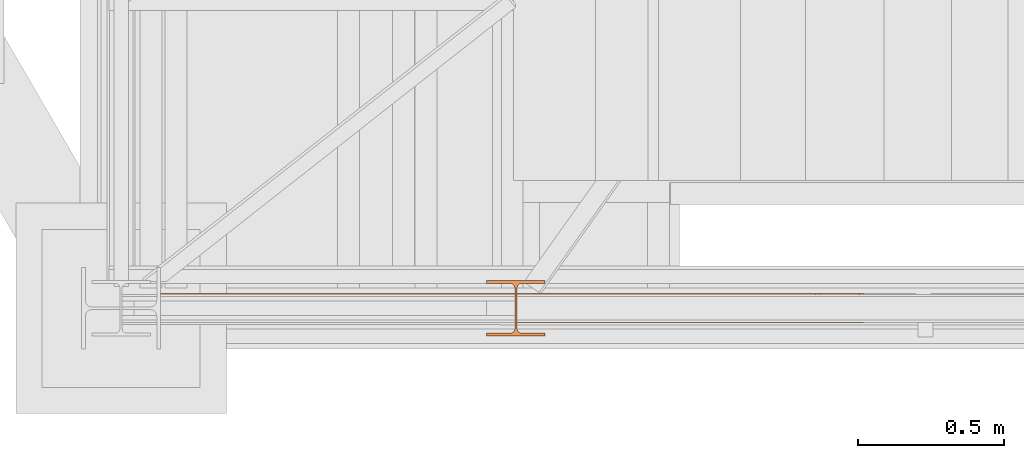
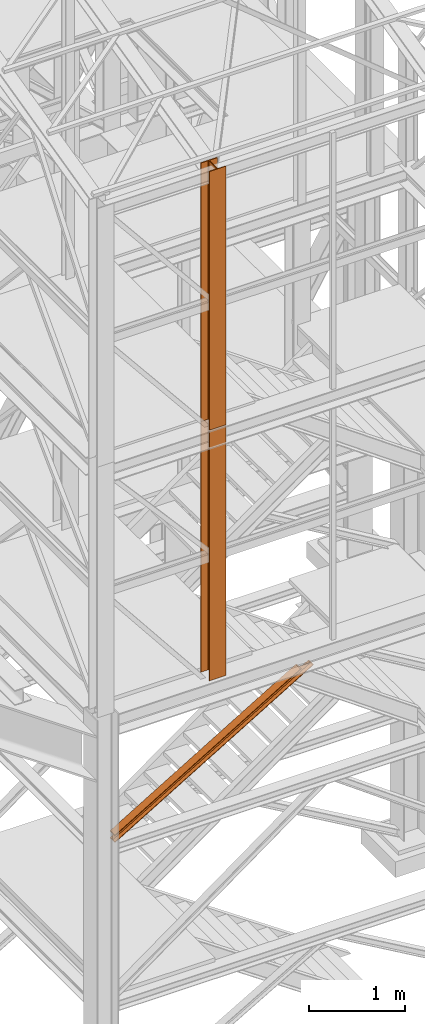
# One storey, part 7 of 208: 3 proxies.
"""IFC2X3 building model written with IfcOpenShell, lengths in millimetres."""

from ifc_helpers import new_model, entity, si_unit, converted_unit, frame, origin, origin_with_axes, place, context, subcontext, project, spatial, faceted_brep, element, save


model = new_model("IFC2X3")

# Units and contexts
model_context = context("Model", 3, precision=1e-05, world=origin())
plan_context = context("Plan", 3, precision=1e-05, world=origin())
body_context = subcontext(model_context, "Body", "Model", "MODEL_VIEW")
ifc_project = project(units=[si_unit("LENGTHUNIT", "METRE", prefix="MILLI"), converted_unit("PLANEANGLEUNIT", "DEGREE", entity("IfcPlaneAngleMeasure", 0.0174532925199433), si_unit("PLANEANGLEUNIT", "RADIAN"), dimensions=[0, 0, 0, 0, 0, 0, 0]), si_unit("AREAUNIT", "SQUARE_METRE"), si_unit("VOLUMEUNIT", "CUBIC_METRE")], contexts=[model_context, plan_context])

# Building, storey
building_placement = place(None, origin())
building = spatial("IfcBuilding", under=ifc_project, at=building_placement, CompositionType="COMPLEX")
storey_placement = place(building_placement, origin_with_axes())
storey = spatial("IfcBuildingStorey", under=building, at=storey_placement, Name="Geschoss", CompositionType="ELEMENT")

# Proxies
proxy_1_placement = place(storey_placement, frame((1333.254973893077, -25222.57439031789, 3580.490000221249), z_axis=(0.0, 0.0, 1.0), x_axis=(1.0, 0.0, 0.0)))
element("IfcBuildingElementProxy", 1, at=proxy_1_placement, inside=storey, context=body_context, shape_type="Brep", body=[
    faceted_brep([(0.009999999999990905, 0.00999999999839929, 88.01000000000022), (0.009999999999990905, 47.5099999999984, 88.01000000000022), (0.009999999999990905, 47.5099999999984, 8.010000000000218), (0.009999999999990905, 0.00999999999839929, 8.010000000000218), (0.009999999999990905, 0.00999999999839929, 0.01000000000021828), (0.009999999999990905, 100.0099999999984, 0.01000000000021828), (0.009999999999990905, 100.0099999999984, 8.010000000000218), (0.009999999999990905, 52.5099999999984, 8.010000000000218), (0.009999999999990905, 52.5099999999984, 88.01000000000022), (0.009999999999990905, 100.0099999999984, 88.01000000000022), (0.009999999999990905, 100.0099999999984, 96.01000000000022), (0.009999999999990905, 0.00999999999839929, 96.01000000000022), (0.009999999999990905, 0.00999999999839929, 96.01000000000022), (2238.627931874558, 0.01000000000203727, 1434.509994414331), (2252.314552726377, 0.01000000000203727, 1434.509994414331), (0.009999999999990905, 0.00999999999839929, 88.01000000000022), (0.009999999999990905, 100.0099999999984, 96.01000000000022), (2238.627931874558, 100.010000000002, 1434.509994414331), (2238.627931874558, 0.01000000000203727, 1434.509994414331), (0.009999999999990905, 0.00999999999839929, 96.01000000000022), (0.009999999999990905, 100.0099999999984, 88.01000000000022), (2252.314552726377, 100.0100000000057, 1434.509994414331), (2238.627931874558, 100.010000000002, 1434.509994414331), (0.009999999999990905, 100.0099999999984, 96.01000000000022), (0.009999999999990905, 52.5099999999984, 88.01000000000022), (2252.314552726377, 52.51000000000204, 1434.509994414331), (2252.314552726377, 100.0100000000057, 1434.509994414331), (0.009999999999990905, 100.0099999999984, 88.01000000000022), (0.009999999999990905, 52.5099999999984, 8.010000000000218), (2389.180761244557, 52.51000000000568, 1434.509994414331), (2252.314552726377, 52.51000000000204, 1434.509994414331), (0.009999999999990905, 52.5099999999984, 88.01000000000022), (0.009999999999990905, 100.0099999999984, 8.010000000000218), (2389.180761244556, 100.0100000000057, 1434.509994414332), (2389.180761244557, 52.51000000000568, 1434.509994414331), (0.009999999999990905, 52.5099999999984, 8.010000000000218), (0.009999999999990905, 100.0099999999984, 0.01000000000021828), (2402.867382096375, 100.0100000000057, 1434.509994414331), (2389.180761244556, 100.0100000000057, 1434.509994414332), (0.009999999999990905, 100.0099999999984, 8.010000000000218), (0.009999999999990905, 0.00999999999839929, 0.01000000000021828), (2402.867382096375, 0.01000000000567525, 1434.509994414331), (2402.867382096375, 100.0100000000057, 1434.509994414331), (0.009999999999990905, 100.0099999999984, 0.01000000000021828), (0.009999999999990905, 0.00999999999839929, 8.010000000000218), (2389.180761244557, 0.01000000000567525, 1434.509994414331), (2402.867382096375, 0.01000000000567525, 1434.509994414331), (0.009999999999990905, 0.00999999999839929, 0.01000000000021828), (0.009999999999990905, 47.5099999999984, 8.010000000000218), (2389.180761244556, 47.51000000000204, 1434.509994414332), (2389.180761244557, 0.01000000000567525, 1434.509994414331), (0.009999999999990905, 0.00999999999839929, 8.010000000000218), (0.009999999999990905, 47.5099999999984, 88.01000000000022), (2252.314552726377, 47.51000000000204, 1434.509994414331), (2389.180761244556, 47.51000000000204, 1434.509994414332), (0.009999999999990905, 47.5099999999984, 8.010000000000218), (0.009999999999990905, 0.00999999999839929, 88.01000000000022), (2252.314552726377, 0.01000000000203727, 1434.509994414331), (2252.314552726377, 47.51000000000204, 1434.509994414331), (0.009999999999990905, 47.5099999999984, 88.01000000000022), (2238.627931874558, 0.01000000000203727, 1434.509994414331), (2238.627931874558, 100.010000000002, 1434.509994414331), (2252.314552726377, 100.0100000000057, 1434.509994414331), (2252.314552726377, 52.51000000000204, 1434.509994414331), (2389.180761244557, 52.51000000000568, 1434.509994414331), (2389.180761244556, 100.0100000000057, 1434.509994414332), (2402.867382096375, 100.0100000000057, 1434.509994414331), (2402.867382096375, 0.01000000000567525, 1434.509994414331), (2389.180761244557, 0.01000000000567525, 1434.509994414331), (2389.180761244556, 47.51000000000204, 1434.509994414332), (2252.314552726377, 47.51000000000204, 1434.509994414331), (2252.314552726377, 0.01000000000203727, 1434.509994414331)], [[[0, 1, 2, 3, 4, 5, 6, 7, 8, 9, 10, 11]], [[12, 13, 14, 15]], [[16, 17, 18, 19]], [[20, 21, 22, 23]], [[24, 25, 26, 27]], [[28, 29, 30, 31]], [[32, 33, 34, 35]], [[36, 37, 38, 39]], [[40, 41, 42, 43]], [[44, 45, 46, 47]], [[48, 49, 50, 51]], [[52, 53, 54, 55]], [[56, 57, 58, 59]], [[60, 61, 62, 63, 64, 65, 66, 67, 68, 69, 70, 71]]], orient=[[False], [False], [False], [False], [False], [False], [False], [False], [False], [False], [False], [False], [False], [False]]),
])
proxy_2_placement = place(storey_placement, frame((2448.254967038549, -25267.57438790133, 5284.990005364416), z_axis=(0.0, 0.0, 1.0), x_axis=(1.0, 0.0, 0.0)))
element("IfcBuildingElementProxy", 2, at=proxy_2_placement, inside=storey, context=body_context, shape_type="Brep", body=[
    faceted_brep([(0.01000000000112777, 190.0100125169738, 3200.009996721741), (200.0100029802334, 190.0100125169738, 3200.009996721741), (200.0100029802334, 180.0100146031364, 3200.009996721741), (121.2600035762798, 180.0100071525558, 3200.009996721741), (111.9441915473353, 178.1454621052726, 3200.009996721741), (105.1245498640847, 171.3258190250381, 3200.009996721741), (103.2600015571725, 162.0100079274162, 3200.009996721741), (103.2600015571725, 28.00999713897545, 3200.009996721741), (105.1245498640847, 18.69418604135353, 3200.009996721741), (111.9441915473353, 11.87454296111901, 3200.009996721741), (121.2600035762798, 10.00999791383583, 3200.009996721741), (200.0100029802334, 10.00999791383583, 3200.009996721741), (200.0100029802334, 0.00999999999839929, 3200.009996721741), (0.01000000000112777, 0.00999999999839929, 3200.009996721741), (0.01000000000112777, 10.00999791383583, 3200.009996721741), (78.75999940395468, 10.00999791383583, 3200.009996721741), (88.07581143289917, 11.87454296111901, 3200.009996721741), (94.89545311614984, 18.69418604135353, 3200.009996721741), (96.76000142306202, 28.00999713897545, 3200.009996721741), (96.76000142306202, 162.0100079274162, 3200.009996721741), (94.89545311614984, 171.3258190250381, 3200.009996721741), (88.07581143289917, 178.1454621052726, 3200.009996721741), (78.75999940395468, 180.0100071525558, 3200.009996721741), (0.01000000000112777, 180.0100146031364, 3200.009996721741), (200.0100029802334, 190.0100125169738, 3200.009996721741), (0.01000000000112777, 190.0100125169738, 3200.009996721741), (0.01000000000021828, 190.0100125169738, 0.009999999999308784), (200.0100029802325, 190.0100125169738, 0.009999999999308784), (200.0100029802334, 180.0100146031364, 3200.009996721741), (200.0100029802334, 190.0100125169738, 3200.009996721741), (200.0100029802325, 190.0100125169738, 0.009999999999308784), (200.0100029802325, 180.0100146031364, 0.009999999999308784), (121.2600035762798, 180.0100071525558, 3200.009996721741), (200.0100029802334, 180.0100146031364, 3200.009996721741), (200.0100029802325, 180.0100146031364, 0.009999999999308784), (121.2600035762789, 180.0100071525558, 0.009999999999308784), (111.9441915473353, 178.1454621052726, 3200.009996721741), (121.2600035762798, 180.0100071525558, 3200.009996721741), (121.2600035762789, 180.0100071525558, 0.009999999999308784), (111.9441915473344, 178.1454621052726, 0.009999999999308784), (105.1245498640847, 171.3258190250381, 3200.009996721741), (111.9441915473353, 178.1454621052726, 3200.009996721741), (111.9441915473344, 178.1454621052726, 0.009999999999308784), (105.1245498640838, 171.3258190250381, 0.009999999999308784), (103.2600015571725, 162.0100079274162, 3200.009996721741), (105.1245498640847, 171.3258190250381, 3200.009996721741), (105.1245498640838, 171.3258190250381, 0.009999999999308784), (103.2600015571716, 162.0100079274162, 0.009999999999308784), (103.2600015571725, 28.00999713897545, 3200.009996721741), (103.2600015571725, 162.0100079274162, 3200.009996721741), (103.2600015571716, 162.0100079274162, 0.009999999999308784), (103.2600015571716, 28.00999713897545, 0.009999999999308784), (105.1245498640847, 18.69418604135353, 3200.009996721741), (103.2600015571725, 28.00999713897545, 3200.009996721741), (103.2600015571716, 28.00999713897545, 0.009999999999308784), (105.1245498640838, 18.69418604135353, 0.009999999999308784), (111.9441915473353, 11.87454296111901, 3200.009996721741), (105.1245498640847, 18.69418604135353, 3200.009996721741), (105.1245498640838, 18.69418604135353, 0.009999999999308784), (111.9441915473344, 11.87454296111901, 0.009999999999308784), (121.2600035762798, 10.00999791383583, 3200.009996721741), (111.9441915473353, 11.87454296111901, 3200.009996721741), (111.9441915473344, 11.87454296111901, 0.009999999999308784), (121.2600035762789, 10.00999791383583, 0.009999999999308784), (200.0100029802334, 10.00999791383583, 3200.009996721741), (121.2600035762798, 10.00999791383583, 3200.009996721741), (121.2600035762789, 10.00999791383583, 0.009999999999308784), (200.0100029802325, 10.00999791383583, 0.009999999999308784), (200.0100029802334, 0.00999999999839929, 3200.009996721741), (200.0100029802334, 10.00999791383583, 3200.009996721741), (200.0100029802325, 10.00999791383583, 0.009999999999308784), (200.0100029802325, 0.00999999999839929, 0.009999999999308784), (0.01000000000112777, 0.00999999999839929, 3200.009996721741), (200.0100029802334, 0.00999999999839929, 3200.009996721741), (200.0100029802325, 0.00999999999839929, 0.009999999999308784), (0.01000000000021828, 0.00999999999839929, 0.009999999999308784), (0.01000000000112777, 10.00999791383583, 3200.009996721741), (0.01000000000112777, 0.00999999999839929, 3200.009996721741), (0.01000000000021828, 0.00999999999839929, 0.009999999999308784), (0.01000000000021828, 10.00999791383583, 0.009999999999308784), (78.75999940395468, 10.00999791383583, 3200.009996721741), (0.01000000000112777, 10.00999791383583, 3200.009996721741), (0.01000000000021828, 10.00999791383583, 0.009999999999308784), (78.75999940395377, 10.00999791383583, 0.009999999999308784), (88.07581143289917, 11.87454296111901, 3200.009996721741), (78.75999940395468, 10.00999791383583, 3200.009996721741), (78.75999940395377, 10.00999791383583, 0.009999999999308784), (88.07581143289826, 11.87454296111901, 0.009999999999308784), (94.89545311614984, 18.69418604135353, 3200.009996721741), (88.07581143289917, 11.87454296111901, 3200.009996721741), (88.07581143289826, 11.87454296111901, 0.009999999999308784), (94.89545311614893, 18.69418604135353, 0.009999999999308784), (96.76000142306202, 28.00999713897545, 3200.009996721741), (94.89545311614984, 18.69418604135353, 3200.009996721741), (94.89545311614893, 18.69418604135353, 0.009999999999308784), (96.76000142306111, 28.00999713897545, 0.009999999999308784), (96.76000142306202, 162.0100079274162, 3200.009996721741), (96.76000142306202, 28.00999713897545, 3200.009996721741), (96.76000142306111, 28.00999713897545, 0.009999999999308784), (96.76000142306111, 162.0100079274162, 0.009999999999308784), (94.89545311614984, 171.3258190250381, 3200.009996721741), (96.76000142306202, 162.0100079274162, 3200.009996721741), (96.76000142306111, 162.0100079274162, 0.009999999999308784), (94.89545311614893, 171.3258190250381, 0.009999999999308784), (88.07581143289917, 178.1454621052726, 3200.009996721741), (94.89545311614984, 171.3258190250381, 3200.009996721741), (94.89545311614893, 171.3258190250381, 0.009999999999308784), (88.07581143289826, 178.1454621052726, 0.009999999999308784), (78.75999940395468, 180.0100071525558, 3200.009996721741), (88.07581143289917, 178.1454621052726, 3200.009996721741), (88.07581143289826, 178.1454621052726, 0.009999999999308784), (78.75999940395377, 180.0100071525558, 0.009999999999308784), (0.01000000000112777, 180.0100146031364, 3200.009996721741), (78.75999940395468, 180.0100071525558, 3200.009996721741), (78.75999940395377, 180.0100071525558, 0.009999999999308784), (0.01000000000021828, 180.0100146031364, 0.009999999999308784), (0.01000000000112777, 190.0100125169738, 3200.009996721741), (0.01000000000112777, 180.0100146031364, 3200.009996721741), (0.01000000000021828, 180.0100146031364, 0.009999999999308784), (0.01000000000021828, 190.0100125169738, 0.009999999999308784), (0.01000000000021828, 190.0100125169738, 0.009999999999308784), (0.01000000000021828, 180.0100146031364, 0.009999999999308784), (78.75999940395377, 180.0100071525558, 0.009999999999308784), (88.07581143289826, 178.1454621052726, 0.009999999999308784), (94.89545311614893, 171.3258190250381, 0.009999999999308784), (96.76000142306111, 162.0100079274162, 0.009999999999308784), (96.76000142306111, 28.00999713897545, 0.009999999999308784), (94.89545311614893, 18.69418604135353, 0.009999999999308784), (88.07581143289826, 11.87454296111901, 0.009999999999308784), (78.75999940395377, 10.00999791383583, 0.009999999999308784), (0.01000000000021828, 10.00999791383583, 0.009999999999308784), (0.01000000000021828, 0.00999999999839929, 0.009999999999308784), (200.0100029802325, 0.00999999999839929, 0.009999999999308784), (200.0100029802325, 10.00999791383583, 0.009999999999308784), (121.2600035762789, 10.00999791383583, 0.009999999999308784), (111.9441915473344, 11.87454296111901, 0.009999999999308784), (105.1245498640838, 18.69418604135353, 0.009999999999308784), (103.2600015571716, 28.00999713897545, 0.009999999999308784), (103.2600015571716, 162.0100079274162, 0.009999999999308784), (105.1245498640838, 171.3258190250381, 0.009999999999308784), (111.9441915473344, 178.1454621052726, 0.009999999999308784), (121.2600035762789, 180.0100071525558, 0.009999999999308784), (200.0100029802325, 180.0100146031364, 0.009999999999308784), (200.0100029802325, 190.0100125169738, 0.009999999999308784)], [[[0, 1, 2, 3, 4, 5, 6, 7, 8, 9, 10, 11, 12, 13, 14, 15, 16, 17, 18, 19, 20, 21, 22, 23]], [[24, 25, 26, 27]], [[28, 29, 30, 31]], [[32, 33, 34, 35]], [[36, 37, 38, 39]], [[40, 41, 42, 43]], [[44, 45, 46, 47]], [[48, 49, 50, 51]], [[52, 53, 54, 55]], [[56, 57, 58, 59]], [[60, 61, 62, 63]], [[64, 65, 66, 67]], [[68, 69, 70, 71]], [[72, 73, 74, 75]], [[76, 77, 78, 79]], [[80, 81, 82, 83]], [[84, 85, 86, 87]], [[88, 89, 90, 91]], [[92, 93, 94, 95]], [[96, 97, 98, 99]], [[100, 101, 102, 103]], [[104, 105, 106, 107]], [[108, 109, 110, 111]], [[112, 113, 114, 115]], [[116, 117, 118, 119]], [[120, 121, 122, 123, 124, 125, 126, 127, 128, 129, 130, 131, 132, 133, 134, 135, 136, 137, 138, 139, 140, 141, 142, 143]]], orient=[[False], [False], [False], [False], [False], [False], [False], [False], [False], [False], [False], [False], [False], [False], [False], [False], [False], [False], [False], [False], [False], [False], [False], [False], [False], [False]]),
])
proxy_3_placement = place(storey_placement, frame((2448.254967038544, -25267.57439657637, 8484.990002086155), z_axis=(0.0, 0.0, 1.0), x_axis=(1.0, 0.0, 0.0)))
element("IfcBuildingElementProxy", 3, at=proxy_3_placement, inside=storey, context=body_context, shape_type="Brep", body=[
    faceted_brep([(0.01000000000021828, 190.010021192018, 3300.392426689976), (200.0100029802325, 190.010021192018, 3300.392426689976), (200.0100029802325, 180.0100232781806, 3300.392426689976), (121.2600035762789, 180.0100158276, 3300.392426689976), (111.9441915473344, 178.1454707803168, 3300.392426689976), (105.1245498640838, 171.3258277000823, 3300.392426689976), (103.2600015571716, 162.0100166024604, 3300.392426689976), (103.2600015571716, 28.01000581401968, 3300.392426689976), (105.1245498640838, 18.69419471639776, 3300.392426689976), (111.9441915473344, 11.87455163616323, 3300.392426689976), (121.2600035762789, 10.01000658888006, 3300.392426689976), (200.0100029802325, 10.01000658888006, 3300.392426689976), (200.0100029802325, 0.01000867504262715, 3300.392426689976), (0.01000000000021828, 0.01000867504262715, 3300.392426689976), (0.01000000000021828, 10.01000658888006, 3300.392426689976), (78.75999940395377, 10.01000658888006, 3300.392426689976), (88.07581143289826, 11.87455163616323, 3300.392426689976), (94.89545311614893, 18.69419471639776, 3300.392426689976), (96.76000142306111, 28.01000581401968, 3300.392426689976), (96.76000142306111, 162.0100166024604, 3300.392426689976), (94.89545311614893, 171.3258277000823, 3300.392426689976), (88.07581143289826, 178.1454707803168, 3300.392426689976), (78.75999940395377, 180.0100158276, 3300.392426689976), (0.01000000000021828, 180.0100232781806, 3300.392426689976), (200.0100029802325, 190.010021192018, 3300.392426689976), (0.01000000000021828, 190.010021192018, 3300.392426689976), (0.01000000000021828, 190.0100125169738, 0.01000000000021828), (200.0100029802325, 190.0100125169738, 0.01000000000021828), (200.0100029802325, 180.0100232781806, 3300.392426689976), (200.0100029802325, 190.010021192018, 3300.392426689976), (200.0100029802325, 190.0100125169738, 0.01000000000021828), (200.0100029802325, 180.0100146031364, 0.01000000000021828), (121.2600035762789, 180.0100158276, 3300.392426689976), (200.0100029802325, 180.0100232781806, 3300.392426689976), (200.0100029802325, 180.0100146031364, 0.01000000000021828), (121.2600035762789, 180.0100071525558, 0.01000000000021828), (111.9441915473344, 178.1454707803168, 3300.392426689976), (121.2600035762789, 180.0100158276, 3300.392426689976), (121.2600035762789, 180.0100071525558, 0.01000000000021828), (111.9441915473344, 178.1454621052726, 0.01000000000021828), (105.1245498640838, 171.3258277000823, 3300.392426689976), (111.9441915473344, 178.1454707803168, 3300.392426689976), (111.9441915473344, 178.1454621052726, 0.01000000000021828), (105.1245498640838, 171.3258190250381, 0.01000000000021828), (103.2600015571716, 162.0100166024604, 3300.392426689976), (105.1245498640838, 171.3258277000823, 3300.392426689976), (105.1245498640838, 171.3258190250381, 0.01000000000021828), (103.2600015571716, 162.0100079274162, 0.01000000000021828), (103.2600015571716, 28.01000581401968, 3300.392426689976), (103.2600015571716, 162.0100166024604, 3300.392426689976), (103.2600015571716, 162.0100079274162, 0.01000000000021828), (103.2600015571716, 28.00999713897545, 0.01000000000021828), (105.1245498640838, 18.69419471639776, 3300.392426689976), (103.2600015571716, 28.01000581401968, 3300.392426689976), (103.2600015571716, 28.00999713897545, 0.01000000000021828), (105.1245498640838, 18.69418604135353, 0.01000000000021828), (111.9441915473344, 11.87455163616323, 3300.392426689976), (105.1245498640838, 18.69419471639776, 3300.392426689976), (105.1245498640838, 18.69418604135353, 0.01000000000021828), (111.9441915473344, 11.87454296111901, 0.01000000000021828), (121.2600035762789, 10.01000658888006, 3300.392426689976), (111.9441915473344, 11.87455163616323, 3300.392426689976), (111.9441915473344, 11.87454296111901, 0.01000000000021828), (121.2600035762789, 10.00999791383583, 0.01000000000021828), (200.0100029802325, 10.01000658888006, 3300.392426689976), (121.2600035762789, 10.01000658888006, 3300.392426689976), (121.2600035762789, 10.00999791383583, 0.01000000000021828), (200.0100029802325, 10.00999791383583, 0.01000000000021828), (200.0100029802325, 0.01000867504262715, 3300.392426689976), (200.0100029802325, 10.01000658888006, 3300.392426689976), (200.0100029802325, 10.00999791383583, 0.01000000000021828), (200.0100029802325, 0.00999999999839929, 0.01000000000021828), (0.01000000000021828, 0.01000867504262715, 3300.392426689976), (200.0100029802325, 0.01000867504262715, 3300.392426689976), (200.0100029802325, 0.00999999999839929, 0.01000000000021828), (0.01000000000021828, 0.00999999999839929, 0.01000000000021828), (0.01000000000021828, 10.01000658888006, 3300.392426689976), (0.01000000000021828, 0.01000867504262715, 3300.392426689976), (0.01000000000021828, 0.00999999999839929, 0.01000000000021828), (0.01000000000021828, 10.00999791383583, 0.01000000000021828), (78.75999940395377, 10.01000658888006, 3300.392426689976), (0.01000000000021828, 10.01000658888006, 3300.392426689976), (0.01000000000021828, 10.00999791383583, 0.01000000000021828), (78.75999940395377, 10.00999791383583, 0.01000000000021828), (88.07581143289826, 11.87455163616323, 3300.392426689976), (78.75999940395377, 10.01000658888006, 3300.392426689976), (78.75999940395377, 10.00999791383583, 0.01000000000021828), (88.07581143289826, 11.87454296111901, 0.01000000000021828), (94.89545311614893, 18.69419471639776, 3300.392426689976), (88.07581143289826, 11.87455163616323, 3300.392426689976), (88.07581143289826, 11.87454296111901, 0.01000000000021828), (94.89545311614893, 18.69418604135353, 0.01000000000021828), (96.76000142306111, 28.01000581401968, 3300.392426689976), (94.89545311614893, 18.69419471639776, 3300.392426689976), (94.89545311614893, 18.69418604135353, 0.01000000000021828), (96.76000142306111, 28.00999713897545, 0.01000000000021828), (96.76000142306111, 162.0100166024604, 3300.392426689976), (96.76000142306111, 28.01000581401968, 3300.392426689976), (96.76000142306111, 28.00999713897545, 0.01000000000021828), (96.76000142306111, 162.0100079274162, 0.01000000000021828), (94.89545311614893, 171.3258277000823, 3300.392426689976), (96.76000142306111, 162.0100166024604, 3300.392426689976), (96.76000142306111, 162.0100079274162, 0.01000000000021828), (94.89545311614893, 171.3258190250381, 0.01000000000021828), (88.07581143289826, 178.1454707803168, 3300.392426689976), (94.89545311614893, 171.3258277000823, 3300.392426689976), (94.89545311614893, 171.3258190250381, 0.01000000000021828), (88.07581143289826, 178.1454621052726, 0.01000000000021828), (78.75999940395377, 180.0100158276, 3300.392426689976), (88.07581143289826, 178.1454707803168, 3300.392426689976), (88.07581143289826, 178.1454621052726, 0.01000000000021828), (78.75999940395377, 180.0100071525558, 0.01000000000021828), (0.01000000000021828, 180.0100232781806, 3300.392426689976), (78.75999940395377, 180.0100158276, 3300.392426689976), (78.75999940395377, 180.0100071525558, 0.01000000000021828), (0.01000000000021828, 180.0100146031364, 0.01000000000021828), (0.01000000000021828, 190.010021192018, 3300.392426689976), (0.01000000000021828, 180.0100232781806, 3300.392426689976), (0.01000000000021828, 180.0100146031364, 0.01000000000021828), (0.01000000000021828, 190.0100125169738, 0.01000000000021828), (0.01000000000021828, 190.0100125169738, 0.01000000000021828), (0.01000000000021828, 180.0100146031364, 0.01000000000021828), (78.75999940395377, 180.0100071525558, 0.01000000000021828), (88.07581143289826, 178.1454621052726, 0.01000000000021828), (94.89545311614893, 171.3258190250381, 0.01000000000021828), (96.76000142306111, 162.0100079274162, 0.01000000000021828), (96.76000142306111, 28.00999713897545, 0.01000000000021828), (94.89545311614893, 18.69418604135353, 0.01000000000021828), (88.07581143289826, 11.87454296111901, 0.01000000000021828), (78.75999940395377, 10.00999791383583, 0.01000000000021828), (0.01000000000021828, 10.00999791383583, 0.01000000000021828), (0.01000000000021828, 0.00999999999839929, 0.01000000000021828), (200.0100029802325, 0.00999999999839929, 0.01000000000021828), (200.0100029802325, 10.00999791383583, 0.01000000000021828), (121.2600035762789, 10.00999791383583, 0.01000000000021828), (111.9441915473344, 11.87454296111901, 0.01000000000021828), (105.1245498640838, 18.69418604135353, 0.01000000000021828), (103.2600015571716, 28.00999713897545, 0.01000000000021828), (103.2600015571716, 162.0100079274162, 0.01000000000021828), (105.1245498640838, 171.3258190250381, 0.01000000000021828), (111.9441915473344, 178.1454621052726, 0.01000000000021828), (121.2600035762789, 180.0100071525558, 0.01000000000021828), (200.0100029802325, 180.0100146031364, 0.01000000000021828), (200.0100029802325, 190.0100125169738, 0.01000000000021828)], [[[0, 1, 2, 3, 4, 5, 6, 7, 8, 9, 10, 11, 12, 13, 14, 15, 16, 17, 18, 19, 20, 21, 22, 23]], [[24, 25, 26, 27]], [[28, 29, 30, 31]], [[32, 33, 34, 35]], [[36, 37, 38, 39]], [[40, 41, 42, 43]], [[44, 45, 46, 47]], [[48, 49, 50, 51]], [[52, 53, 54, 55]], [[56, 57, 58, 59]], [[60, 61, 62, 63]], [[64, 65, 66, 67]], [[68, 69, 70, 71]], [[72, 73, 74, 75]], [[76, 77, 78, 79]], [[80, 81, 82, 83]], [[84, 85, 86, 87]], [[88, 89, 90, 91]], [[92, 93, 94, 95]], [[96, 97, 98, 99]], [[100, 101, 102, 103]], [[104, 105, 106, 107]], [[108, 109, 110, 111]], [[112, 113, 114, 115]], [[116, 117, 118, 119]], [[120, 121, 122, 123, 124, 125, 126, 127, 128, 129, 130, 131, 132, 133, 134, 135, 136, 137, 138, 139, 140, 141, 142, 143]]], orient=[[False], [False], [False], [False], [False], [False], [False], [False], [False], [False], [False], [False], [False], [False], [False], [False], [False], [False], [False], [False], [False], [False], [False], [False], [False], [False]]),
])

save(model, "model.ifc")
